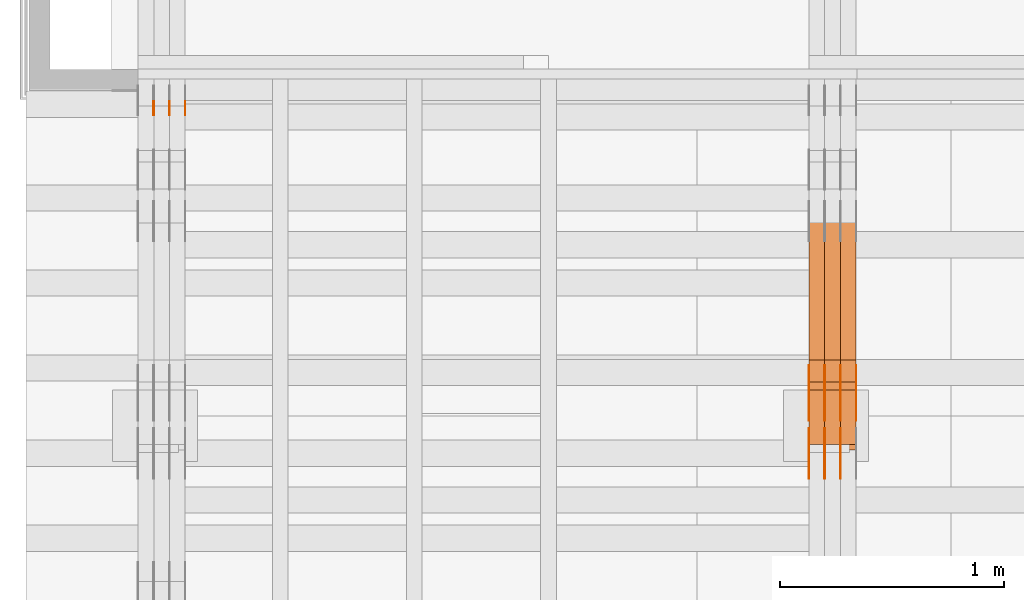
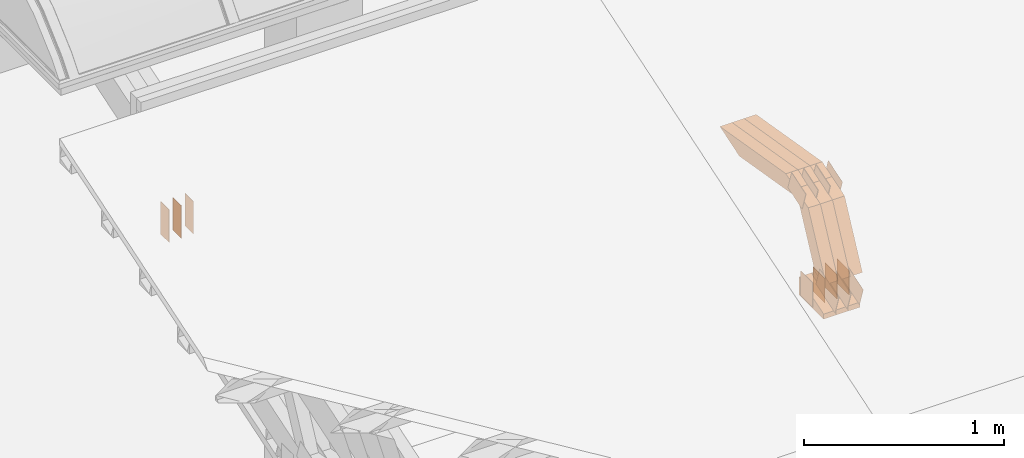
# One storey, part 76 of 385: 30 proxies.
"""IFC2X3 building model written with IfcOpenShell, lengths in millimetres."""

from ifc_helpers import new_model, entity, si_unit, converted_unit, derived_unit, direction, frame, frame_2d, origin, place, context, subcontext, project, spatial, polyline, rectangle, outline, extrude, source, transform, mapped, material, type_object, type_shapes, element, save


model = new_model("IFC2X3")

# Units and contexts
model_context = context("Model", 3, precision=0.01, world=origin(), true_north=direction((6.12303176911189e-17, 1.0)))
body_context = subcontext(model_context, "Body", "Model", "MODEL_VIEW")
ifc_project = project(units=[si_unit("LENGTHUNIT", "METRE", prefix="MILLI"), si_unit("AREAUNIT", "SQUARE_METRE"), si_unit("VOLUMEUNIT", "CUBIC_METRE"), converted_unit("PLANEANGLEUNIT", "DEGREE", entity("IfcRatioMeasure", 0.0174532925199433), si_unit("PLANEANGLEUNIT", "RADIAN"), dimensions=[0, 0, 0, 0, 0, 0, 0]), si_unit("MASSUNIT", "GRAM", prefix="KILO"), derived_unit("MASSDENSITYUNIT", [(si_unit("MASSUNIT", "GRAM", prefix="KILO"), 1), (si_unit("LENGTHUNIT", "METRE"), -3)]), si_unit("TIMEUNIT", "SECOND"), si_unit("FREQUENCYUNIT", "HERTZ"), si_unit("THERMODYNAMICTEMPERATUREUNIT", "DEGREE_CELSIUS"), derived_unit("THERMALTRANSMITTANCEUNIT", [(si_unit("MASSUNIT", "GRAM", prefix="KILO"), 1), (si_unit("THERMODYNAMICTEMPERATUREUNIT", "KELVIN"), -1), (si_unit("TIMEUNIT", "SECOND"), -3)]), derived_unit("VOLUMETRICFLOWRATEUNIT", [(si_unit("LENGTHUNIT", "METRE"), 3), (si_unit("TIMEUNIT", "SECOND"), -1)]), si_unit("ELECTRICCURRENTUNIT", "AMPERE"), si_unit("ELECTRICVOLTAGEUNIT", "VOLT"), si_unit("POWERUNIT", "WATT"), si_unit("FORCEUNIT", "NEWTON", prefix="KILO"), si_unit("ILLUMINANCEUNIT", "LUX"), si_unit("LUMINOUSFLUXUNIT", "LUMEN"), si_unit("LUMINOUSINTENSITYUNIT", "CANDELA"), derived_unit("USERDEFINED", [(si_unit("MASSUNIT", "GRAM", prefix="KILO"), -1), (si_unit("LENGTHUNIT", "METRE"), -2), (si_unit("TIMEUNIT", "SECOND"), 3), (si_unit("LUMINOUSFLUXUNIT", "LUMEN"), 1)]), derived_unit("LINEARVELOCITYUNIT", [(si_unit("LENGTHUNIT", "METRE"), 1), (si_unit("TIMEUNIT", "SECOND"), -1)]), si_unit("PRESSUREUNIT", "PASCAL"), derived_unit("USERDEFINED", [(si_unit("LENGTHUNIT", "METRE"), -2), (si_unit("MASSUNIT", "GRAM", prefix="KILO"), 1), (si_unit("TIMEUNIT", "SECOND"), -2)])], contexts=[model_context])

# Site, building, storey
site_placement = place(None, origin())
site = spatial("IfcSite", under=ifc_project, at=site_placement, CompositionType="ELEMENT")
building_placement = place(site_placement, origin())
building = spatial("IfcBuilding", under=site, at=building_placement, CompositionType="ELEMENT")
storey_placement = place(building_placement, origin())
storey = spatial("IfcBuildingStorey", under=building, at=storey_placement, Name="Default", CompositionType="ELEMENT", Elevation=0.0)

# Proxies
ifc_material_1 = material(Name="IfcSurfaceStyle #69246")
building_element_proxy_type_1 = type_object("IfcBuildingElementProxyType", PredefinedType="NOTDEFINED", material=ifc_material_1)
shared_shape_1 = source(origin(), body_context, "Body", "SweptSolid", [
    extrude(outline(polyline([(-99.9997874178038, -60.0000528641967), (99.9998102700997, -60.0000528641967), (99.9998251396068, 60.0000528641967), (-99.9998479919027, 60.0000528641967), (-99.9997874178038, -60.0000528641967)])), frame((99.9999918898597, 60.0000528641967, 0.0), z_axis=(0.0, 0.0, 1.0), x_axis=(-1.0, 0.0, 0.0)), (0.0, 0.0, 1.0), 1.3),
])
type_shapes(building_element_proxy_type_1, [shared_shape_1])
proxy_1_placement = place(building_placement, frame((3316.29999999999, 11991.9568177725, 3072.52282247925), z_axis=(-1.0, 0.0, 0.0), x_axis=(0.0, 0.951056516295124, 0.309016994375039)))
element("IfcBuildingElementProxy", 1, at=proxy_1_placement, inside=storey, type_object=building_element_proxy_type_1, material=ifc_material_1, context=body_context, shape_type="MappedRepresentation", body=[
    mapped(shared_shape_1, transform((0.0, 0.0, 0.0), scale=1.0)),
])
ifc_material_2 = material(Name="IfcSurfaceStyle #69189")
building_element_proxy_type_2 = type_object("IfcBuildingElementProxyType", PredefinedType="NOTDEFINED", material=ifc_material_2)
shared_shape_2 = source(origin(), body_context, "Body", "SweptSolid", [
    extrude(outline(polyline([(-99.9997874178038, -60.0000528641967), (99.9998102700997, -60.0000528641967), (99.9998251396068, 60.0000528641967), (-99.9998479919027, 60.0000528641967), (-99.9997874178038, -60.0000528641967)])), frame((99.9999918898597, 60.0000528641967, 0.0), z_axis=(0.0, 0.0, 1.0), x_axis=(-1.0, 0.0, 0.0)), (0.0, 0.0, 1.0), 1.29999999999998),
])
type_shapes(building_element_proxy_type_2, [shared_shape_2])
proxy_2_placement = place(building_placement, frame((3245.0, 11991.9568177725, 3072.52282247925), z_axis=(-1.0, 0.0, 0.0), x_axis=(0.0, 0.951056516295124, 0.309016994375039)))
element("IfcBuildingElementProxy", 2, at=proxy_2_placement, inside=storey, type_object=building_element_proxy_type_2, material=ifc_material_2, context=body_context, shape_type="MappedRepresentation", body=[
    mapped(shared_shape_2, transform((0.0, 0.0, 0.0), scale=1.0)),
])
ifc_material_3 = material(Name="IfcSurfaceStyle #69132")
building_element_proxy_type_3 = type_object("IfcBuildingElementProxyType", PredefinedType="NOTDEFINED", material=ifc_material_3)
shared_shape_3 = source(origin(), body_context, "Body", "SweptSolid", [
    extrude(outline(polyline([(-99.9997874178038, -60.0000528641967), (99.9998102700997, -60.0000528641967), (99.9998251396068, 60.0000528641967), (-99.9998479919027, 60.0000528641967), (-99.9997874178038, -60.0000528641967)])), frame((99.9999918898597, 60.0000528641967, 0.0), z_axis=(0.0, 0.0, 1.0), x_axis=(-1.0, 0.0, 0.0)), (0.0, 0.0, 1.0), 1.29999999999998),
])
type_shapes(building_element_proxy_type_3, [shared_shape_3])
proxy_3_placement = place(building_placement, frame((3246.29999999999, 11991.9568177725, 3072.52282247925), z_axis=(-1.0, 0.0, 0.0), x_axis=(0.0, 0.951056516295124, 0.309016994375039)))
element("IfcBuildingElementProxy", 3, at=proxy_3_placement, inside=storey, type_object=building_element_proxy_type_3, material=ifc_material_3, context=body_context, shape_type="MappedRepresentation", body=[
    mapped(shared_shape_3, transform((0.0, 0.0, 0.0), scale=1.0)),
])
ifc_material_4 = material(Name="IfcSurfaceStyle #69075")
building_element_proxy_type_4 = type_object("IfcBuildingElementProxyType", PredefinedType="NOTDEFINED", material=ifc_material_4)
shared_shape_4 = source(origin(), body_context, "Body", "SweptSolid", [
    extrude(outline(polyline([(-99.9997874178038, -60.0000528641967), (99.9998102700997, -60.0000528641967), (99.9998251396068, 60.0000528641967), (-99.9998479919027, 60.0000528641967), (-99.9997874178038, -60.0000528641967)])), frame((99.9999918898597, 60.0000528641967, 0.0), z_axis=(0.0, 0.0, 1.0), x_axis=(-1.0, 0.0, 0.0)), (0.0, 0.0, 1.0), 1.29999999999999),
])
type_shapes(building_element_proxy_type_4, [shared_shape_4])
proxy_4_placement = place(building_placement, frame((3175.0, 11991.9568177725, 3072.52282247925), z_axis=(-1.0, 0.0, 0.0), x_axis=(0.0, 0.951056516295124, 0.309016994375039)))
element("IfcBuildingElementProxy", 4, at=proxy_4_placement, inside=storey, type_object=building_element_proxy_type_4, material=ifc_material_4, context=body_context, shape_type="MappedRepresentation", body=[
    mapped(shared_shape_4, transform((0.0, 0.0, 0.0), scale=1.0)),
])
ifc_material_5 = material(Name="IfcSurfaceStyle #69018")
building_element_proxy_type_5 = type_object("IfcBuildingElementProxyType", PredefinedType="NOTDEFINED", material=ifc_material_5)
shared_shape_5 = source(origin(), body_context, "Body", "SweptSolid", [
    extrude(rectangle(XDim=150.0, YDim=119.999999999985, at=frame_2d((-7.105427357601e-15, 0.0), x_axis=(1.0, 0.0))), frame((75.0, 60.0, 0.0), z_axis=(0.0, 0.0, 1.0), x_axis=(-1.0, 0.0, 0.0)), (0.0, 0.0, 1.0), 1.3),
])
type_shapes(building_element_proxy_type_5, [shared_shape_5])
proxy_5_placement = place(building_placement, frame((3386.29999999999, 12372.95703125, 3007.04687500001), z_axis=(-1.0, 0.0, 0.0), x_axis=(0.0, 0.0, -1.0)))
element("IfcBuildingElementProxy", 5, at=proxy_5_placement, inside=storey, type_object=building_element_proxy_type_5, material=ifc_material_5, context=body_context, shape_type="MappedRepresentation", body=[
    mapped(shared_shape_5, transform((0.0, 0.0, 0.0), scale=1.0)),
])
ifc_material_6 = material(Name="IfcSurfaceStyle #68961")
building_element_proxy_type_6 = type_object("IfcBuildingElementProxyType", PredefinedType="NOTDEFINED", material=ifc_material_6)
shared_shape_6 = source(origin(), body_context, "Body", "SweptSolid", [
    extrude(rectangle(XDim=150.0, YDim=119.999999999985, at=frame_2d((-7.105427357601e-15, 0.0), x_axis=(1.0, 0.0))), frame((75.0, 60.0, 0.0), z_axis=(0.0, 0.0, 1.0), x_axis=(-1.0, 0.0, 0.0)), (0.0, 0.0, 1.0), 1.3),
])
type_shapes(building_element_proxy_type_6, [shared_shape_6])
proxy_6_placement = place(building_placement, frame((3315.0, 12372.95703125, 3007.04687500001), z_axis=(-1.0, 0.0, 0.0), x_axis=(0.0, 0.0, -1.0)))
element("IfcBuildingElementProxy", 6, at=proxy_6_placement, inside=storey, type_object=building_element_proxy_type_6, material=ifc_material_6, context=body_context, shape_type="MappedRepresentation", body=[
    mapped(shared_shape_6, transform((0.0, 0.0, 0.0), scale=1.0)),
])
ifc_material_7 = material(Name="IfcSurfaceStyle #68904")
building_element_proxy_type_7 = type_object("IfcBuildingElementProxyType", PredefinedType="NOTDEFINED", material=ifc_material_7)
shared_shape_7 = source(origin(), body_context, "Body", "SweptSolid", [
    extrude(rectangle(XDim=150.0, YDim=119.999999999985, at=frame_2d((-7.105427357601e-15, 0.0), x_axis=(1.0, 0.0))), frame((75.0, 60.0, 0.0), z_axis=(0.0, 0.0, 1.0), x_axis=(-1.0, 0.0, 0.0)), (0.0, 0.0, 1.0), 1.3),
])
type_shapes(building_element_proxy_type_7, [shared_shape_7])
proxy_7_placement = place(building_placement, frame((3316.29999999999, 12372.95703125, 3007.04687500001), z_axis=(-1.0, 0.0, 0.0), x_axis=(0.0, 0.0, -1.0)))
element("IfcBuildingElementProxy", 7, at=proxy_7_placement, inside=storey, type_object=building_element_proxy_type_7, material=ifc_material_7, context=body_context, shape_type="MappedRepresentation", body=[
    mapped(shared_shape_7, transform((0.0, 0.0, 0.0), scale=1.0)),
])
ifc_material_8 = material(Name="IfcSurfaceStyle #68847")
building_element_proxy_type_8 = type_object("IfcBuildingElementProxyType", PredefinedType="NOTDEFINED", material=ifc_material_8)
shared_shape_8 = source(origin(), body_context, "Body", "SweptSolid", [
    extrude(rectangle(XDim=150.0, YDim=119.999999999985, at=frame_2d((-7.105427357601e-15, 0.0), x_axis=(1.0, 0.0))), frame((75.0, 60.0, 0.0), z_axis=(0.0, 0.0, 1.0), x_axis=(-1.0, 0.0, 0.0)), (0.0, 0.0, 1.0), 1.29999999999999),
])
type_shapes(building_element_proxy_type_8, [shared_shape_8])
proxy_8_placement = place(building_placement, frame((3245.0, 12372.95703125, 3007.04687500001), z_axis=(-1.0, 0.0, 0.0), x_axis=(0.0, 0.0, -1.0)))
element("IfcBuildingElementProxy", 8, at=proxy_8_placement, inside=storey, type_object=building_element_proxy_type_8, material=ifc_material_8, context=body_context, shape_type="MappedRepresentation", body=[
    mapped(shared_shape_8, transform((0.0, 0.0, 0.0), scale=1.0)),
])
ifc_material_9 = material(Name="IfcSurfaceStyle #68790")
building_element_proxy_type_9 = type_object("IfcBuildingElementProxyType", PredefinedType="NOTDEFINED", material=ifc_material_9)
shared_shape_9 = source(origin(), body_context, "Body", "SweptSolid", [
    extrude(rectangle(XDim=150.0, YDim=119.999999999985, at=frame_2d((-7.105427357601e-15, 0.0), x_axis=(1.0, 0.0))), frame((75.0, 60.0, 0.0), z_axis=(0.0, 0.0, 1.0), x_axis=(-1.0, 0.0, 0.0)), (0.0, 0.0, 1.0), 1.29999999999999),
])
type_shapes(building_element_proxy_type_9, [shared_shape_9])
proxy_9_placement = place(building_placement, frame((3246.29999999999, 12372.95703125, 3007.04687500001), z_axis=(-1.0, 0.0, 0.0), x_axis=(0.0, 0.0, -1.0)))
element("IfcBuildingElementProxy", 9, at=proxy_9_placement, inside=storey, type_object=building_element_proxy_type_9, material=ifc_material_9, context=body_context, shape_type="MappedRepresentation", body=[
    mapped(shared_shape_9, transform((0.0, 0.0, 0.0), scale=1.0)),
])
ifc_material_10 = material(Name="IfcSurfaceStyle #68733")
building_element_proxy_type_10 = type_object("IfcBuildingElementProxyType", PredefinedType="NOTDEFINED", material=ifc_material_10)
shared_shape_10 = source(origin(), body_context, "Body", "SweptSolid", [
    extrude(rectangle(XDim=150.0, YDim=119.999999999985, at=frame_2d((-7.105427357601e-15, 0.0), x_axis=(1.0, 0.0))), frame((75.0, 60.0, 0.0), z_axis=(0.0, 0.0, 1.0), x_axis=(-1.0, 0.0, 0.0)), (0.0, 0.0, 1.0), 1.29999999999999),
])
type_shapes(building_element_proxy_type_10, [shared_shape_10])
proxy_10_placement = place(building_placement, frame((3175.0, 12372.95703125, 3007.04687500001), z_axis=(-1.0, 0.0, 0.0), x_axis=(0.0, 0.0, -1.0)))
element("IfcBuildingElementProxy", 10, at=proxy_10_placement, inside=storey, type_object=building_element_proxy_type_10, material=ifc_material_10, context=body_context, shape_type="MappedRepresentation", body=[
    mapped(shared_shape_10, transform((0.0, 0.0, 0.0), scale=1.0)),
])
ifc_material_11 = material(Name="IfcSurfaceStyle #61836")
building_element_proxy_type_11 = type_object("IfcBuildingElementProxyType", PredefinedType="NOTDEFINED", material=ifc_material_11)
shared_shape_11 = source(origin(), body_context, "Body", "SweptSolid", [
    extrude(outline(polyline([(-74.9998754286244, -60.0000016373506), (74.9998605591063, -60.0000016373506), (74.9998754286244, 60.0000016373506), (-74.9998605591063, 60.0000016373506), (-74.9998754286244, -60.0000016373506)])), frame((74.9998754286244, 60.0000016373506, 0.0), z_axis=(0.0, 0.0, 1.0), x_axis=(-1.0, 0.0, 0.0)), (0.0, 0.0, 1.0), 1.3),
])
type_shapes(building_element_proxy_type_11, [shared_shape_11])
proxy_11_placement = place(building_placement, frame((3386.29999999999, 12321.1620861463, 3506.17707344366), z_axis=(-1.0, 0.0, 0.0), x_axis=(0.0, 0.951056516295154, 0.309016994374948)))
element("IfcBuildingElementProxy", 11, at=proxy_11_placement, inside=storey, type_object=building_element_proxy_type_11, material=ifc_material_11, context=body_context, shape_type="MappedRepresentation", body=[
    mapped(shared_shape_11, transform((0.0, 0.0, 0.0), scale=1.0)),
])
ifc_material_12 = material(Name="IfcSurfaceStyle #61779")
building_element_proxy_type_12 = type_object("IfcBuildingElementProxyType", PredefinedType="NOTDEFINED", material=ifc_material_12)
shared_shape_12 = source(origin(), body_context, "Body", "SweptSolid", [
    extrude(outline(polyline([(-74.9998754286244, -60.0000016373506), (74.9998605591063, -60.0000016373506), (74.9998754286244, 60.0000016373506), (-74.9998605591063, 60.0000016373506), (-74.9998754286244, -60.0000016373506)])), frame((74.9998754286244, 60.0000016373506, 0.0), z_axis=(0.0, 0.0, 1.0), x_axis=(-1.0, 0.0, 0.0)), (0.0, 0.0, 1.0), 1.3),
])
type_shapes(building_element_proxy_type_12, [shared_shape_12])
proxy_12_placement = place(building_placement, frame((3315.0, 12321.1620861463, 3506.17707344366), z_axis=(-1.0, 0.0, 0.0), x_axis=(0.0, 0.951056516295154, 0.309016994374948)))
element("IfcBuildingElementProxy", 12, at=proxy_12_placement, inside=storey, type_object=building_element_proxy_type_12, material=ifc_material_12, context=body_context, shape_type="MappedRepresentation", body=[
    mapped(shared_shape_12, transform((0.0, 0.0, 0.0), scale=1.0)),
])
ifc_material_13 = material(Name="IfcSurfaceStyle #61722")
building_element_proxy_type_13 = type_object("IfcBuildingElementProxyType", PredefinedType="NOTDEFINED", material=ifc_material_13)
shared_shape_13 = source(origin(), body_context, "Body", "SweptSolid", [
    extrude(outline(polyline([(-74.9998754286244, -60.0000016373506), (74.9998605591063, -60.0000016373506), (74.9998754286244, 60.0000016373506), (-74.9998605591063, 60.0000016373506), (-74.9998754286244, -60.0000016373506)])), frame((74.9998754286244, 60.0000016373506, 0.0), z_axis=(0.0, 0.0, 1.0), x_axis=(-1.0, 0.0, 0.0)), (0.0, 0.0, 1.0), 1.3),
])
type_shapes(building_element_proxy_type_13, [shared_shape_13])
proxy_13_placement = place(building_placement, frame((3316.29999999999, 12321.1620861463, 3506.17707344366), z_axis=(-1.0, 0.0, 0.0), x_axis=(0.0, 0.951056516295154, 0.309016994374948)))
element("IfcBuildingElementProxy", 13, at=proxy_13_placement, inside=storey, type_object=building_element_proxy_type_13, material=ifc_material_13, context=body_context, shape_type="MappedRepresentation", body=[
    mapped(shared_shape_13, transform((0.0, 0.0, 0.0), scale=1.0)),
])
ifc_material_14 = material(Name="IfcSurfaceStyle #61665")
building_element_proxy_type_14 = type_object("IfcBuildingElementProxyType", PredefinedType="NOTDEFINED", material=ifc_material_14)
shared_shape_14 = source(origin(), body_context, "Body", "SweptSolid", [
    extrude(outline(polyline([(-74.9998754286244, -60.0000016373506), (74.9998605591063, -60.0000016373506), (74.9998754286244, 60.0000016373506), (-74.9998605591063, 60.0000016373506), (-74.9998754286244, -60.0000016373506)])), frame((74.9998754286244, 60.0000016373506, 0.0), z_axis=(0.0, 0.0, 1.0), x_axis=(-1.0, 0.0, 0.0)), (0.0, 0.0, 1.0), 1.29999999999999),
])
type_shapes(building_element_proxy_type_14, [shared_shape_14])
proxy_14_placement = place(building_placement, frame((3245.0, 12321.1620861463, 3506.17707344366), z_axis=(-1.0, 0.0, 0.0), x_axis=(0.0, 0.951056516295154, 0.309016994374948)))
element("IfcBuildingElementProxy", 14, at=proxy_14_placement, inside=storey, type_object=building_element_proxy_type_14, material=ifc_material_14, context=body_context, shape_type="MappedRepresentation", body=[
    mapped(shared_shape_14, transform((0.0, 0.0, 0.0), scale=1.0)),
])
ifc_material_15 = material(Name="IfcSurfaceStyle #61608")
building_element_proxy_type_15 = type_object("IfcBuildingElementProxyType", PredefinedType="NOTDEFINED", material=ifc_material_15)
shared_shape_15 = source(origin(), body_context, "Body", "SweptSolid", [
    extrude(outline(polyline([(-74.9998754286244, -60.0000016373506), (74.9998605591063, -60.0000016373506), (74.9998754286244, 60.0000016373506), (-74.9998605591063, 60.0000016373506), (-74.9998754286244, -60.0000016373506)])), frame((74.9998754286244, 60.0000016373506, 0.0), z_axis=(0.0, 0.0, 1.0), x_axis=(-1.0, 0.0, 0.0)), (0.0, 0.0, 1.0), 1.29999999999999),
])
type_shapes(building_element_proxy_type_15, [shared_shape_15])
proxy_15_placement = place(building_placement, frame((3246.29999999999, 12321.1620861463, 3506.17707344366), z_axis=(-1.0, 0.0, 0.0), x_axis=(0.0, 0.951056516295154, 0.309016994374948)))
element("IfcBuildingElementProxy", 15, at=proxy_15_placement, inside=storey, type_object=building_element_proxy_type_15, material=ifc_material_15, context=body_context, shape_type="MappedRepresentation", body=[
    mapped(shared_shape_15, transform((0.0, 0.0, 0.0), scale=1.0)),
])
ifc_material_16 = material(Name="IfcSurfaceStyle #61551")
building_element_proxy_type_16 = type_object("IfcBuildingElementProxyType", PredefinedType="NOTDEFINED", material=ifc_material_16)
shared_shape_16 = source(origin(), body_context, "Body", "SweptSolid", [
    extrude(outline(polyline([(-74.9998754286244, -60.0000016373506), (74.9998605591063, -60.0000016373506), (74.9998754286244, 60.0000016373506), (-74.9998605591063, 60.0000016373506), (-74.9998754286244, -60.0000016373506)])), frame((74.9998754286244, 60.0000016373506, 0.0), z_axis=(0.0, 0.0, 1.0), x_axis=(-1.0, 0.0, 0.0)), (0.0, 0.0, 1.0), 1.29999999999999),
])
type_shapes(building_element_proxy_type_16, [shared_shape_16])
proxy_16_placement = place(building_placement, frame((3175.0, 12321.1620861463, 3506.17707344366), z_axis=(-1.0, 0.0, 0.0), x_axis=(0.0, 0.951056516295154, 0.309016994374948)))
element("IfcBuildingElementProxy", 16, at=proxy_16_placement, inside=storey, type_object=building_element_proxy_type_16, material=ifc_material_16, context=body_context, shape_type="MappedRepresentation", body=[
    mapped(shared_shape_16, transform((0.0, 0.0, 0.0), scale=1.0)),
])
ifc_material_17 = material(Name="IfcSurfaceStyle #53376")
building_element_proxy_type_17 = type_object("IfcBuildingElementProxyType", Name="T1-E1 53374", PredefinedType="NOTDEFINED", material=ifc_material_17)
shared_shape_17 = source(origin(), body_context, "Body", "SweptSolid", [
    extrude(outline(polyline([(-75.1378173828004, -122.500000000005), (35.3350830078246, -122.500000000005), (35.3350830078004, 122.500000000005), (4.46765136717545, 122.500000000005), (-75.1378173828004, -122.500000000005)])), frame((35.3350830078246, 122.500000104877, 0.0), z_axis=(0.0, 0.0, 1.0), x_axis=(-1.0, 0.0, 0.0)), (0.0, 0.0, 1.0), 70.0),
])
type_shapes(building_element_proxy_type_17, [shared_shape_17])
proxy_17_placement = place(building_placement, frame((3385.0, 12145.0, 2849.54565429685), z_axis=(-1.0, 0.0, 0.0), x_axis=(0.0, 0.0, 1.0)))
element("IfcBuildingElementProxy", 17, at=proxy_17_placement, inside=storey, type_object=building_element_proxy_type_17, material=ifc_material_17, Name="T1-E1", context=body_context, shape_type="MappedRepresentation", body=[
    mapped(shared_shape_17, transform((0.0, 0.0, 0.0), scale=1.0)),
])
ifc_material_18 = material(Name="IfcSurfaceStyle #53319")
building_element_proxy_type_18 = type_object("IfcBuildingElementProxyType", Name="T1-E1 53317", PredefinedType="NOTDEFINED", material=ifc_material_18)
shared_shape_18 = source(origin(), body_context, "Body", "SweptSolid", [
    extrude(outline(polyline([(-75.1378173828004, -122.500000000005), (35.3350830078246, -122.500000000005), (35.3350830078004, 122.500000000005), (4.46765136717545, 122.500000000005), (-75.1378173828004, -122.500000000005)])), frame((35.3350830078246, 122.500000104877, 0.0), z_axis=(0.0, 0.0, 1.0), x_axis=(-1.0, 0.0, 0.0)), (0.0, 0.0, 1.0), 70.0),
])
type_shapes(building_element_proxy_type_18, [shared_shape_18])
proxy_18_placement = place(building_placement, frame((3315.0, 12145.0, 2849.54565429685), z_axis=(-1.0, 0.0, 0.0), x_axis=(0.0, 0.0, 1.0)))
element("IfcBuildingElementProxy", 18, at=proxy_18_placement, inside=storey, type_object=building_element_proxy_type_18, material=ifc_material_18, Name="T1-E1", context=body_context, shape_type="MappedRepresentation", body=[
    mapped(shared_shape_18, transform((0.0, 0.0, 0.0), scale=1.0)),
])
ifc_material_19 = material(Name="IfcSurfaceStyle #53262")
building_element_proxy_type_19 = type_object("IfcBuildingElementProxyType", Name="T1-E1 53260", PredefinedType="NOTDEFINED", material=ifc_material_19)
shared_shape_19 = source(origin(), body_context, "Body", "SweptSolid", [
    extrude(outline(polyline([(-75.1378173828004, -122.500000000005), (35.3350830078246, -122.500000000005), (35.3350830078004, 122.500000000005), (4.46765136717545, 122.500000000005), (-75.1378173828004, -122.500000000005)])), frame((35.3350830078246, 122.500000104877, 0.0), z_axis=(0.0, 0.0, 1.0), x_axis=(-1.0, 0.0, 0.0)), (0.0, 0.0, 1.0), 70.0),
])
type_shapes(building_element_proxy_type_19, [shared_shape_19])
proxy_19_placement = place(building_placement, frame((3245.0, 12145.0, 2849.54565429685), z_axis=(-1.0, 0.0, 0.0), x_axis=(0.0, 0.0, 1.0)))
element("IfcBuildingElementProxy", 19, at=proxy_19_placement, inside=storey, type_object=building_element_proxy_type_19, material=ifc_material_19, Name="T1-E1", context=body_context, shape_type="MappedRepresentation", body=[
    mapped(shared_shape_19, transform((0.0, 0.0, 0.0), scale=1.0)),
])
ifc_material_20 = material(Name="IfcSurfaceStyle #51648")
building_element_proxy_type_20 = type_object("IfcBuildingElementProxyType", Name="T1-W7 51646", PredefinedType="NOTDEFINED", material=ifc_material_20)
shared_shape_20 = source(origin(), body_context, "Body", "SweptSolid", [
    extrude(outline(polyline([(-296.174043820986, -47.5000676566704), (297.841254477443, -47.5000676566704), (283.518570346415, -7.10254316533821e-06), (192.674144473719, 47.500071207942), (-477.859925476591, 47.500071207942), (-296.174043820986, -47.5000676566704)])), frame((297.841254477443, 47.5000816097442, 0.0), z_axis=(0.0, 0.0, 1.0), x_axis=(-1.0, 0.0, 0.0)), (0.0, 0.0, 1.0), 70.0),
])
type_shapes(building_element_proxy_type_20, [shared_shape_20])
proxy_20_placement = place(building_placement, frame((3385.0, 12419.2991208897, 3526.2136755972), z_axis=(-1.0, 0.0, 0.0), x_axis=(0.0, 0.985983815111804, -0.166840991178939)))
element("IfcBuildingElementProxy", 20, at=proxy_20_placement, inside=storey, type_object=building_element_proxy_type_20, material=ifc_material_20, Name="T1-W7", context=body_context, shape_type="MappedRepresentation", body=[
    mapped(shared_shape_20, transform((0.0, 0.0, 0.0), scale=1.0)),
])
ifc_material_21 = material(Name="IfcSurfaceStyle #51582")
building_element_proxy_type_21 = type_object("IfcBuildingElementProxyType", Name="T1-W7 51580", PredefinedType="NOTDEFINED", material=ifc_material_21)
shared_shape_21 = source(origin(), body_context, "Body", "SweptSolid", [
    extrude(outline(polyline([(-296.174043820986, -47.5000676566704), (297.841254477443, -47.5000676566704), (283.518570346415, -7.10254316533821e-06), (192.674144473719, 47.500071207942), (-477.859925476591, 47.500071207942), (-296.174043820986, -47.5000676566704)])), frame((297.841254477443, 47.5000816097442, 0.0), z_axis=(0.0, 0.0, 1.0), x_axis=(-1.0, 0.0, 0.0)), (0.0, 0.0, 1.0), 70.0),
])
type_shapes(building_element_proxy_type_21, [shared_shape_21])
proxy_21_placement = place(building_placement, frame((3315.0, 12419.2991208897, 3526.2136755972), z_axis=(-1.0, 0.0, 0.0), x_axis=(0.0, 0.985983815111804, -0.166840991178939)))
element("IfcBuildingElementProxy", 21, at=proxy_21_placement, inside=storey, type_object=building_element_proxy_type_21, material=ifc_material_21, Name="T1-W7", context=body_context, shape_type="MappedRepresentation", body=[
    mapped(shared_shape_21, transform((0.0, 0.0, 0.0), scale=1.0)),
])
ifc_material_22 = material(Name="IfcSurfaceStyle #51516")
building_element_proxy_type_22 = type_object("IfcBuildingElementProxyType", Name="T1-W7 51514", PredefinedType="NOTDEFINED", material=ifc_material_22)
shared_shape_22 = source(origin(), body_context, "Body", "SweptSolid", [
    extrude(outline(polyline([(-296.174043820986, -47.5000676566704), (297.841254477443, -47.5000676566704), (283.518570346415, -7.10254316533821e-06), (192.674144473719, 47.500071207942), (-477.859925476591, 47.500071207942), (-296.174043820986, -47.5000676566704)])), frame((297.841254477443, 47.5000816097442, 0.0), z_axis=(0.0, 0.0, 1.0), x_axis=(-1.0, 0.0, 0.0)), (0.0, 0.0, 1.0), 70.0),
])
type_shapes(building_element_proxy_type_22, [shared_shape_22])
proxy_22_placement = place(building_placement, frame((3245.0, 12419.2991208897, 3526.2136755972), z_axis=(-1.0, 0.0, 0.0), x_axis=(0.0, 0.985983815111804, -0.166840991178939)))
element("IfcBuildingElementProxy", 22, at=proxy_22_placement, inside=storey, type_object=building_element_proxy_type_22, material=ifc_material_22, Name="T1-W7", context=body_context, shape_type="MappedRepresentation", body=[
    mapped(shared_shape_22, transform((0.0, 0.0, 0.0), scale=1.0)),
])
ifc_material_23 = material(Name="IfcSurfaceStyle #51252")
building_element_proxy_type_23 = type_object("IfcBuildingElementProxyType", Name="T1-W36 51250", PredefinedType="NOTDEFINED", material=ifc_material_23)
shared_shape_23 = source(origin(), body_context, "Body", "SweptSolid", [
    extrude(outline(polyline([(-300.714670922549, -47.4998881108849), (134.031527004269, -47.499888110885), (180.52054953879, -0.000136170977331764), (193.89900152221, 47.500563476126), (-207.736407142719, 47.4993489166213), (-300.714670922549, -47.4998881108849)])), frame((193.899145164686, 47.5001861375837, 0.0), z_axis=(0.0, 0.0, 1.0), x_axis=(-1.0, 3.02403492980632e-06, 0.0)), (0.0, 0.0, 1.0), 70.0),
])
type_shapes(building_element_proxy_type_23, [shared_shape_23])
proxy_23_placement = place(building_placement, frame((3385.0, 12120.5935627532, 3076.1128858536), z_axis=(-1.0, 0.0, 0.0), x_axis=(0.0, 0.444384650266842, 0.895836080210669)))
element("IfcBuildingElementProxy", 23, at=proxy_23_placement, inside=storey, type_object=building_element_proxy_type_23, material=ifc_material_23, Name="T1-W36", context=body_context, shape_type="MappedRepresentation", body=[
    mapped(shared_shape_23, transform((0.0, 0.0, 0.0), scale=1.0)),
])
ifc_material_24 = material(Name="IfcSurfaceStyle #51186")
building_element_proxy_type_24 = type_object("IfcBuildingElementProxyType", Name="T1-W36 51184", PredefinedType="NOTDEFINED", material=ifc_material_24)
shared_shape_24 = source(origin(), body_context, "Body", "SweptSolid", [
    extrude(outline(polyline([(-300.714670922549, -47.4998881108849), (134.031527004269, -47.499888110885), (180.52054953879, -0.000136170977331764), (193.89900152221, 47.500563476126), (-207.736407142719, 47.4993489166213), (-300.714670922549, -47.4998881108849)])), frame((193.899145164686, 47.5001861375837, 0.0), z_axis=(0.0, 0.0, 1.0), x_axis=(-1.0, 3.02403492980632e-06, 0.0)), (0.0, 0.0, 1.0), 70.0),
])
type_shapes(building_element_proxy_type_24, [shared_shape_24])
proxy_24_placement = place(building_placement, frame((3315.0, 12120.5935627532, 3076.1128858536), z_axis=(-1.0, 0.0, 0.0), x_axis=(0.0, 0.444384650266842, 0.895836080210669)))
element("IfcBuildingElementProxy", 24, at=proxy_24_placement, inside=storey, type_object=building_element_proxy_type_24, material=ifc_material_24, Name="T1-W36", context=body_context, shape_type="MappedRepresentation", body=[
    mapped(shared_shape_24, transform((0.0, 0.0, 0.0), scale=1.0)),
])
ifc_material_25 = material(Name="IfcSurfaceStyle #51120")
building_element_proxy_type_25 = type_object("IfcBuildingElementProxyType", Name="T1-W36 51118", PredefinedType="NOTDEFINED", material=ifc_material_25)
shared_shape_25 = source(origin(), body_context, "Body", "SweptSolid", [
    extrude(outline(polyline([(-300.714670922549, -47.4998881108849), (134.031527004269, -47.499888110885), (180.52054953879, -0.000136170977331764), (193.89900152221, 47.500563476126), (-207.736407142719, 47.4993489166213), (-300.714670922549, -47.4998881108849)])), frame((193.899145164686, 47.5001861375837, 0.0), z_axis=(0.0, 0.0, 1.0), x_axis=(-1.0, 3.02403492980632e-06, 0.0)), (0.0, 0.0, 1.0), 70.0),
])
type_shapes(building_element_proxy_type_25, [shared_shape_25])
proxy_25_placement = place(building_placement, frame((3245.0, 12120.5935627532, 3076.1128858536), z_axis=(-1.0, 0.0, 0.0), x_axis=(0.0, 0.444384650266842, 0.895836080210669)))
element("IfcBuildingElementProxy", 25, at=proxy_25_placement, inside=storey, type_object=building_element_proxy_type_25, material=ifc_material_25, Name="T1-W36", context=body_context, shape_type="MappedRepresentation", body=[
    mapped(shared_shape_25, transform((0.0, 0.0, 0.0), scale=1.0)),
])
ifc_material_26 = material(Name="IfcSurfaceStyle #36980")
building_element_proxy_type_26 = type_object("IfcBuildingElementProxyType", PredefinedType="NOTDEFINED", material=ifc_material_26)
shared_shape_26 = source(origin(), body_context, "Body", "SweptSolid", [
    extrude(rectangle(XDim=200.0, YDim=84.0, at=frame_2d((0.0, -7.105427357601e-15), x_axis=(1.0, 0.0))), frame((100.0, 42.0, 0.0), z_axis=(0.0, 0.0, 1.0), x_axis=(-1.0, 0.0, 0.0)), (0.0, 0.0, 1.0), 1.3),
])
type_shapes(building_element_proxy_type_26, [shared_shape_26])
proxy_26_placement = place(building_placement, frame((386.299999999986, 13702.0, 3651.4150390625), z_axis=(-1.0, 0.0, 0.0), x_axis=(0.0, 0.0, -1.0)))
element("IfcBuildingElementProxy", 26, at=proxy_26_placement, inside=storey, type_object=building_element_proxy_type_26, material=ifc_material_26, context=body_context, shape_type="MappedRepresentation", body=[
    mapped(shared_shape_26, transform((0.0, 0.0, 0.0), scale=1.0)),
])
ifc_material_27 = material(Name="IfcSurfaceStyle #36923")
building_element_proxy_type_27 = type_object("IfcBuildingElementProxyType", PredefinedType="NOTDEFINED", material=ifc_material_27)
shared_shape_27 = source(origin(), body_context, "Body", "SweptSolid", [
    extrude(rectangle(XDim=200.0, YDim=84.0, at=frame_2d((0.0, -7.105427357601e-15), x_axis=(1.0, 0.0))), frame((100.0, 42.0, 0.0), z_axis=(0.0, 0.0, 1.0), x_axis=(-1.0, 0.0, 0.0)), (0.0, 0.0, 1.0), 1.3),
])
type_shapes(building_element_proxy_type_27, [shared_shape_27])
proxy_27_placement = place(building_placement, frame((315.0, 13702.0, 3651.4150390625), z_axis=(-1.0, 0.0, 0.0), x_axis=(0.0, 0.0, -1.0)))
element("IfcBuildingElementProxy", 27, at=proxy_27_placement, inside=storey, type_object=building_element_proxy_type_27, material=ifc_material_27, context=body_context, shape_type="MappedRepresentation", body=[
    mapped(shared_shape_27, transform((0.0, 0.0, 0.0), scale=1.0)),
])
ifc_material_28 = material(Name="IfcSurfaceStyle #36866")
building_element_proxy_type_28 = type_object("IfcBuildingElementProxyType", PredefinedType="NOTDEFINED", material=ifc_material_28)
shared_shape_28 = source(origin(), body_context, "Body", "SweptSolid", [
    extrude(rectangle(XDim=200.0, YDim=84.0, at=frame_2d((0.0, -7.105427357601e-15), x_axis=(1.0, 0.0))), frame((100.0, 42.0, 0.0), z_axis=(0.0, 0.0, 1.0), x_axis=(-1.0, 0.0, 0.0)), (0.0, 0.0, 1.0), 1.3),
])
type_shapes(building_element_proxy_type_28, [shared_shape_28])
proxy_28_placement = place(building_placement, frame((316.299999999986, 13702.0, 3651.4150390625), z_axis=(-1.0, 0.0, 0.0), x_axis=(0.0, 0.0, -1.0)))
element("IfcBuildingElementProxy", 28, at=proxy_28_placement, inside=storey, type_object=building_element_proxy_type_28, material=ifc_material_28, context=body_context, shape_type="MappedRepresentation", body=[
    mapped(shared_shape_28, transform((0.0, 0.0, 0.0), scale=1.0)),
])
ifc_material_29 = material(Name="IfcSurfaceStyle #36809")
building_element_proxy_type_29 = type_object("IfcBuildingElementProxyType", PredefinedType="NOTDEFINED", material=ifc_material_29)
shared_shape_29 = source(origin(), body_context, "Body", "SweptSolid", [
    extrude(rectangle(XDim=200.0, YDim=84.0, at=frame_2d((0.0, -7.105427357601e-15), x_axis=(1.0, 0.0))), frame((100.0, 42.0, 0.0), z_axis=(0.0, 0.0, 1.0), x_axis=(-1.0, 0.0, 0.0)), (0.0, 0.0, 1.0), 1.29999999999998),
])
type_shapes(building_element_proxy_type_29, [shared_shape_29])
proxy_29_placement = place(building_placement, frame((245.0, 13702.0, 3651.4150390625), z_axis=(-1.0, 0.0, 0.0), x_axis=(0.0, 0.0, -1.0)))
element("IfcBuildingElementProxy", 29, at=proxy_29_placement, inside=storey, type_object=building_element_proxy_type_29, material=ifc_material_29, context=body_context, shape_type="MappedRepresentation", body=[
    mapped(shared_shape_29, transform((0.0, 0.0, 0.0), scale=1.0)),
])
ifc_material_30 = material(Name="IfcSurfaceStyle #36752")
building_element_proxy_type_30 = type_object("IfcBuildingElementProxyType", PredefinedType="NOTDEFINED", material=ifc_material_30)
shared_shape_30 = source(origin(), body_context, "Body", "SweptSolid", [
    extrude(rectangle(XDim=200.0, YDim=84.0, at=frame_2d((0.0, -7.105427357601e-15), x_axis=(1.0, 0.0))), frame((100.0, 42.0, 0.0), z_axis=(0.0, 0.0, 1.0), x_axis=(-1.0, 0.0, 0.0)), (0.0, 0.0, 1.0), 1.29999999999998),
])
type_shapes(building_element_proxy_type_30, [shared_shape_30])
proxy_30_placement = place(building_placement, frame((246.299999999986, 13702.0, 3651.4150390625), z_axis=(-1.0, 0.0, 0.0), x_axis=(0.0, 0.0, -1.0)))
element("IfcBuildingElementProxy", 30, at=proxy_30_placement, inside=storey, type_object=building_element_proxy_type_30, material=ifc_material_30, context=body_context, shape_type="MappedRepresentation", body=[
    mapped(shared_shape_30, transform((0.0, 0.0, 0.0), scale=1.0)),
])

save(model, "model.ifc")
